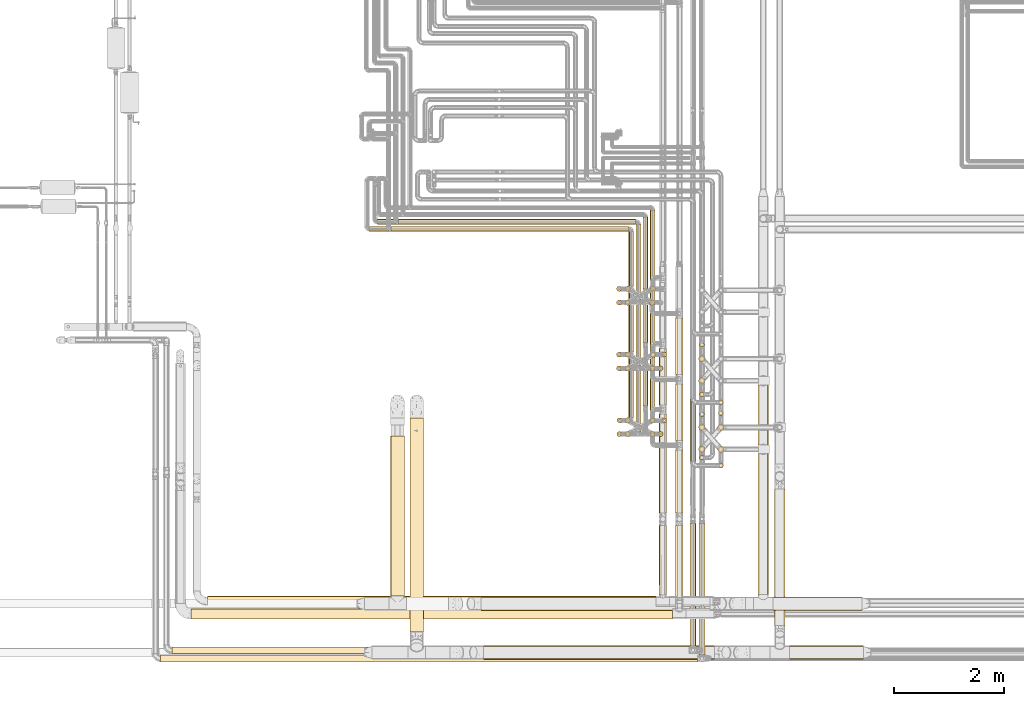
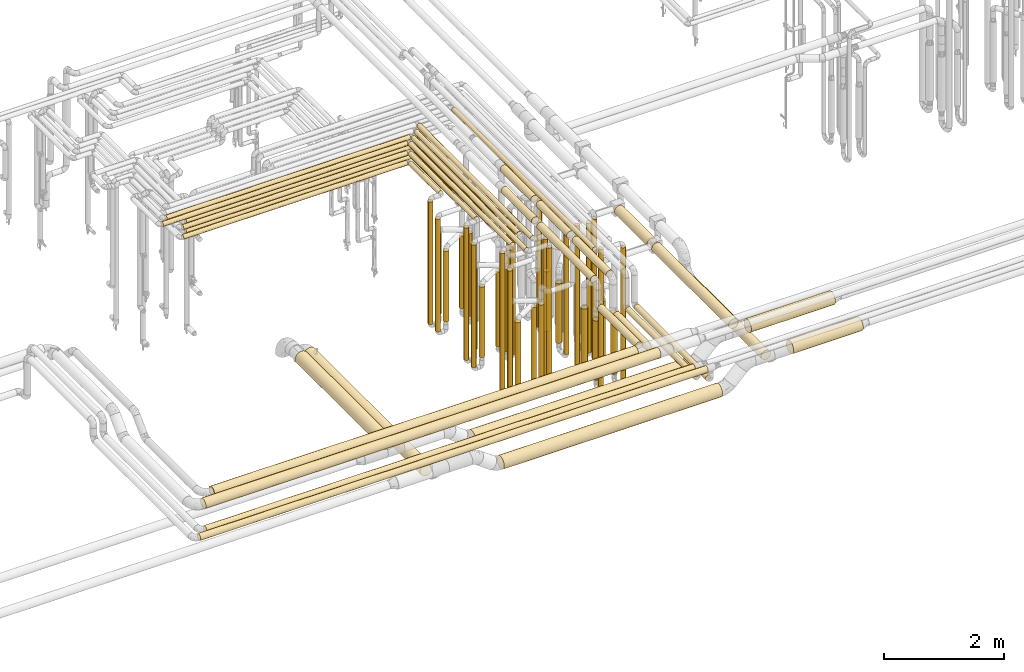
# One storey, part 4 of 824: 76 coverings.
"""IFC2X3 building model written with IfcOpenShell, lengths in millimetres."""

from ifc_helpers import new_model, entity, si_unit, converted_unit, derived_unit, direction, frame, origin, origin_2d_with_axis, place, context, subcontext, project, spatial, circle, extrude, element, save


model = new_model("IFC2X3")

# Units and contexts
model_context = context("Model", 3, precision=0.01, world=origin(), true_north=direction((6.12303176911189e-17, 1.0)))
body_context = subcontext(model_context, "Body", "Model", "MODEL_VIEW")
ifc_project = project(units=[si_unit("LENGTHUNIT", "METRE", prefix="MILLI"), si_unit("AREAUNIT", "SQUARE_METRE"), si_unit("VOLUMEUNIT", "CUBIC_METRE"), converted_unit("PLANEANGLEUNIT", "DEGREE", entity("IfcRatioMeasure", 0.0174532925199433), si_unit("PLANEANGLEUNIT", "RADIAN"), dimensions=[0, 0, 0, 0, 0, 0, 0]), si_unit("MASSUNIT", "GRAM", prefix="KILO"), derived_unit("MASSDENSITYUNIT", [(si_unit("MASSUNIT", "GRAM", prefix="KILO"), 1), (si_unit("LENGTHUNIT", "METRE"), -3)]), derived_unit("MOMENTOFINERTIAUNIT", [(si_unit("LENGTHUNIT", "METRE"), 4)]), si_unit("TIMEUNIT", "SECOND"), si_unit("FREQUENCYUNIT", "HERTZ"), si_unit("THERMODYNAMICTEMPERATUREUNIT", "DEGREE_CELSIUS"), derived_unit("THERMALTRANSMITTANCEUNIT", [(si_unit("MASSUNIT", "GRAM", prefix="KILO"), 1), (si_unit("THERMODYNAMICTEMPERATUREUNIT", "KELVIN"), -1), (si_unit("TIMEUNIT", "SECOND"), -3)]), derived_unit("VOLUMETRICFLOWRATEUNIT", [(si_unit("LENGTHUNIT", "METRE"), 3), (si_unit("TIMEUNIT", "SECOND"), -1)]), derived_unit("MASSFLOWRATEUNIT", [(si_unit("MASSUNIT", "GRAM", prefix="KILO"), 1), (si_unit("TIMEUNIT", "SECOND"), -1)]), derived_unit("ROTATIONALFREQUENCYUNIT", [(si_unit("TIMEUNIT", "SECOND"), -1)]), si_unit("ELECTRICCURRENTUNIT", "AMPERE"), si_unit("ELECTRICVOLTAGEUNIT", "VOLT"), si_unit("POWERUNIT", "WATT"), si_unit("FORCEUNIT", "NEWTON", prefix="KILO"), si_unit("ILLUMINANCEUNIT", "LUX"), si_unit("LUMINOUSFLUXUNIT", "LUMEN"), si_unit("LUMINOUSINTENSITYUNIT", "CANDELA"), derived_unit("USERDEFINED", [(si_unit("MASSUNIT", "GRAM", prefix="KILO"), -1), (si_unit("LENGTHUNIT", "METRE"), -2), (si_unit("TIMEUNIT", "SECOND"), 3), (si_unit("LUMINOUSFLUXUNIT", "LUMEN"), 1)]), derived_unit("LINEARVELOCITYUNIT", [(si_unit("LENGTHUNIT", "METRE"), 1), (si_unit("TIMEUNIT", "SECOND"), -1)]), si_unit("PRESSUREUNIT", "PASCAL"), derived_unit("USERDEFINED", [(si_unit("LENGTHUNIT", "METRE"), -2), (si_unit("MASSUNIT", "GRAM", prefix="KILO"), 1), (si_unit("TIMEUNIT", "SECOND"), -2)]), derived_unit("LINEARFORCEUNIT", [(si_unit("MASSUNIT", "GRAM", prefix="KILO"), 1), (si_unit("LENGTHUNIT", "METRE"), 1), (si_unit("TIMEUNIT", "SECOND"), -2), (si_unit("LENGTHUNIT", "METRE"), -1)]), derived_unit("PLANARFORCEUNIT", [(si_unit("MASSUNIT", "GRAM", prefix="KILO"), 1), (si_unit("LENGTHUNIT", "METRE"), 1), (si_unit("TIMEUNIT", "SECOND"), -2), (si_unit("LENGTHUNIT", "METRE"), -2)])], contexts=[model_context])

# Site, building, storey
site_placement = place(None, origin())
site = spatial("IfcSite", under=ifc_project, at=site_placement, CompositionType="ELEMENT")
building_placement = place(site_placement, origin())
building = spatial("IfcBuilding", under=site, at=building_placement, CompositionType="ELEMENT")
storey_placement = place(building_placement, frame((0.0, 0.0, 28200.0)))
storey = spatial("IfcBuildingStorey", under=building, at=storey_placement, CompositionType="ELEMENT", Elevation=28200.0)

# Coverings
covering_1_placement = place(storey_placement, frame((35072.29, 11508.46, 448.0)))
element("IfcCovering", 1, at=covering_1_placement, inside=storey, PredefinedType="INSULATION", context=body_context, shape_type="SweptSolid", body=[
    extrude(circle(Radius=46.15, at=origin_2d_with_axis()), frame((47.75, 47.75, 0.0), z_axis=(0.0, 0.0, 1.0), x_axis=(0.0, -1.0, 0.0)), (0.0, 0.0, 1.0), 2504.00000000002),
])
covering_2_placement = place(storey_placement, frame((35895.3, 11758.46, 448.0)))
element("IfcCovering", 2, at=covering_2_placement, inside=storey, PredefinedType="INSULATION", context=body_context, shape_type="SweptSolid", body=[
    extrude(circle(Radius=46.15, at=origin_2d_with_axis()), frame((47.75, 47.75, 0.0)), (0.0, 0.0, 1.0), 2704.00000000003),
])
covering_3_placement = place(storey_placement, frame((35077.29, 10309.34, 448.0)))
element("IfcCovering", 3, at=covering_3_placement, inside=storey, PredefinedType="INSULATION", context=body_context, shape_type="SweptSolid", body=[
    extrude(circle(Radius=46.15, at=origin_2d_with_axis()), frame((47.75, 47.75, 0.0), z_axis=(0.0, 0.0, 1.0), x_axis=(0.0, -1.0, 0.0)), (0.0, 0.0, 1.0), 2704.00000000001),
])
covering_4_placement = place(storey_placement, frame((35900.3, 10558.46, 448.0)))
element("IfcCovering", 4, at=covering_4_placement, inside=storey, PredefinedType="INSULATION", context=body_context, shape_type="SweptSolid", body=[
    extrude(circle(Radius=46.15, at=origin_2d_with_axis()), frame((47.75, 47.75, 0.0), z_axis=(0.0, 0.0, 1.0), x_axis=(-1.0, 0.0, 0.0)), (0.0, 0.0, 1.0), 2904.00000000001),
])
covering_5_placement = place(storey_placement, frame((35847.22, 8921.39, 3479.16)))
element("IfcCovering", 5, at=covering_5_placement, inside=storey, PredefinedType="INSULATION", context=body_context, shape_type="SweptSolid", body=[
    extrude(circle(Radius=69.25, at=origin_2d_with_axis()), frame((70.85, 0.0, 70.85), z_axis=(0.0, 1.0, -9.11558874934062e-08), x_axis=(1.0, 0.0, 0.0)), (0.0, 0.0, 1.0), 1798.81487069227),
])
covering_6_placement = place(storey_placement, frame((35847.2, 7422.68, 3029.15)))
element("IfcCovering", 6, at=covering_6_placement, inside=storey, PredefinedType="INSULATION", context=body_context, shape_type="SweptSolid", body=[
    extrude(circle(Radius=69.25, at=origin_2d_with_axis()), frame((70.85, 1270.71, 70.85), z_axis=(0.000807635041357438, -0.999999673862767, 0.0), x_axis=(0.999999673862767, 0.000807635041357438, 0.0)), (0.0, 0.0, 1.0), 1270.65564093337),
])
covering_7_placement = place(storey_placement, frame((35682.29, 11854.2, 3152.25)))
element("IfcCovering", 7, at=covering_7_placement, inside=storey, PredefinedType="INSULATION", context=body_context, shape_type="SweptSolid", body=[
    extrude(circle(Radius=46.15, at=origin_2d_with_axis()), frame((47.75, 0.0, 47.75), z_axis=(0.0, 1.0, 0.0), x_axis=(-1.0, 0.0, 0.0)), (0.0, 0.0, 1.0), 2587.79707398043),
])
covering_8_placement = place(storey_placement, frame((35552.35, 12031.2, 3152.25)))
element("IfcCovering", 8, at=covering_8_placement, inside=storey, PredefinedType="INSULATION", context=body_context, shape_type="SweptSolid", body=[
    extrude(circle(Radius=46.15, at=origin_2d_with_axis()), frame((47.75, 0.0, 47.75), z_axis=(0.0, 1.0, 0.0), x_axis=(1.0, 0.0, 0.0)), (0.0, 0.0, 1.0), 2280.79727405418),
])
covering_9_placement = place(storey_placement, frame((35682.29, 10654.2, 3352.25)))
element("IfcCovering", 9, at=covering_9_placement, inside=storey, PredefinedType="INSULATION", context=body_context, shape_type="SweptSolid", body=[
    extrude(circle(Radius=46.15, at=origin_2d_with_axis()), frame((47.75, 0.0, 47.75), z_axis=(0.0, 1.0, 0.0), x_axis=(1.0, 0.0, 0.0)), (0.0, 0.0, 1.0), 3787.79707398042),
])
covering_10_placement = place(storey_placement, frame((35552.35, 10876.38, 3352.25)))
element("IfcCovering", 10, at=covering_10_placement, inside=storey, PredefinedType="INSULATION", context=body_context, shape_type="SweptSolid", body=[
    extrude(circle(Radius=46.15, at=origin_2d_with_axis()), frame((47.75, 0.0, 47.75), z_axis=(0.0, 1.0, 0.0), x_axis=(1.0, 0.0, 0.0)), (0.0, 0.0, 1.0), 3435.62396825438),
])
covering_11_placement = place(storey_placement, frame((35847.22, 10892.2, 3479.16)))
element("IfcCovering", 11, at=covering_11_placement, inside=storey, PredefinedType="INSULATION", context=body_context, shape_type="SweptSolid", body=[
    extrude(circle(Radius=69.25, at=origin_2d_with_axis()), frame((70.85, 0.0, 70.85), z_axis=(0.0, 1.0, -9.11558935474048e-08), x_axis=(1.0, 0.0, 0.0)), (0.0, 0.0, 1.0), 1027.87693556046),
])
covering_12_placement = place(storey_placement, frame((35228.27, 10306.49, 604.0)))
element("IfcCovering", 12, at=covering_12_placement, inside=storey, PredefinedType="INSULATION", context=body_context, shape_type="SweptSolid", body=[
    extrude(circle(Radius=49.0, at=origin_2d_with_axis()), frame((50.6, 50.6, 0.0), z_axis=(0.0, 1.97430995600526e-06, 1.0), x_axis=(-1.0, 0.0, 0.0)), (0.0, 0.0, 1.0), 1439.00000000281),
])
covering_13_placement = place(storey_placement, frame((35677.45, 10555.61, 559.0)))
element("IfcCovering", 13, at=covering_13_placement, inside=storey, PredefinedType="INSULATION", context=body_context, shape_type="SweptSolid", body=[
    extrude(circle(Radius=49.0, at=origin_2d_with_axis()), frame((50.6, 50.6, 0.0), z_axis=(0.0, 0.0, 1.0), x_axis=(-1.0, 0.0, 0.0)), (0.0, 0.0, 1.0), 1484.0),
])
covering_14_placement = place(storey_placement, frame((35224.44, 11505.05, 603.98)))
element("IfcCovering", 14, at=covering_14_placement, inside=storey, PredefinedType="INSULATION", context=body_context, shape_type="SweptSolid", body=[
    extrude(circle(Radius=49.0, at=origin_2d_with_axis()), frame((50.6, 51.21, 0.02), z_axis=(0.0, -0.000429537009763512, 0.999999907748974), x_axis=(1.0, 0.0, 0.0)), (0.0, 0.0, 1.0), 1438.97359676792),
])
covering_15_placement = place(storey_placement, frame((35686.26, 11755.07, 511.98)))
element("IfcCovering", 15, at=covering_15_placement, inside=storey, PredefinedType="INSULATION", context=body_context, shape_type="SweptSolid", body=[
    extrude(circle(Radius=49.0, at=origin_2d_with_axis()), frame((50.6, 51.09, 0.02), z_axis=(0.0, -0.000321811119658756, 0.9999999482188), x_axis=(1.0, 0.0, 0.0)), (0.0, 0.0, 1.0), 1531.00008703173),
])
covering_16_placement = place(storey_placement, frame((27310.33, 6983.4, 3003.4)))
element("IfcCovering", 16, at=covering_16_placement, inside=storey, PredefinedType="INSULATION", context=body_context, shape_type="SweptSolid", body=[
    extrude(circle(Radius=95.0, at=origin_2d_with_axis()), frame((0.0, 96.6, 96.6), z_axis=(1.0, 0.0, 0.0), x_axis=(0.0, -0.707106781186544, -0.707106781186551)), (0.0, 0.0, 1.0), 8785.70070250989),
])
covering_17_placement = place(storey_placement, frame((31094.52, 14182.26, 3152.25)))
element("IfcCovering", 17, at=covering_17_placement, inside=storey, PredefinedType="INSULATION", context=body_context, shape_type="SweptSolid", body=[
    extrude(circle(Radius=46.15, at=origin_2d_with_axis()), frame((0.0, 47.75, 47.75), z_axis=(1.0, 0.0, 0.0), x_axis=(0.0, -1.0, 0.0)), (0.0, 0.0, 1.0), 4327.51165000006),
])
covering_18_placement = place(storey_placement, frame((30964.52, 14052.26, 3152.25)))
element("IfcCovering", 18, at=covering_18_placement, inside=storey, PredefinedType="INSULATION", context=body_context, shape_type="SweptSolid", body=[
    extrude(circle(Radius=46.15, at=origin_2d_with_axis()), frame((0.0, 47.75, 47.75), z_axis=(1.0, 0.0, 0.0), x_axis=(0.0, -1.0, 0.0)), (0.0, 0.0, 1.0), 4327.51165000005),
])
covering_19_placement = place(storey_placement, frame((30718.34, 14182.26, 3352.25)))
element("IfcCovering", 19, at=covering_19_placement, inside=storey, PredefinedType="INSULATION", context=body_context, shape_type="SweptSolid", body=[
    extrude(circle(Radius=46.15, at=origin_2d_with_axis()), frame((0.0, 47.75, 47.75), z_axis=(1.0, 0.0, 0.0), x_axis=(0.0, -1.0, 0.0)), (0.0, 0.0, 1.0), 4703.69587000002),
])
covering_20_placement = place(storey_placement, frame((30569.52, 14052.26, 3352.25)))
element("IfcCovering", 20, at=covering_20_placement, inside=storey, PredefinedType="INSULATION", context=body_context, shape_type="SweptSolid", body=[
    extrude(circle(Radius=46.15, at=origin_2d_with_axis()), frame((0.0, 47.75, 47.75), z_axis=(1.0, 0.0, 0.0), x_axis=(0.0, -1.0, 0.0)), (0.0, 0.0, 1.0), 4722.51165000002),
])
covering_21_placement = place(storey_placement, frame((35072.29, 11758.46, 448.0)))
element("IfcCovering", 21, at=covering_21_placement, inside=storey, PredefinedType="INSULATION", context=body_context, shape_type="SweptSolid", body=[
    extrude(circle(Radius=46.15, at=origin_2d_with_axis()), frame((47.75, 47.75, 0.0), z_axis=(0.0, 0.0, 1.0), x_axis=(0.0, -1.0, 0.0)), (0.0, 0.0, 1.0), 2704.00000000002),
])
covering_22_placement = place(storey_placement, frame((35826.04, 11508.42, 448.0)))
element("IfcCovering", 22, at=covering_22_placement, inside=storey, PredefinedType="INSULATION", context=body_context, shape_type="SweptSolid", body=[
    extrude(circle(Radius=46.15, at=origin_2d_with_axis()), frame((47.75, 47.75, 0.0), z_axis=(0.0, 0.0, 1.0), x_axis=(-1.0, 0.0, 0.0)), (0.0, 0.0, 1.0), 2704.00000000003),
])
covering_23_placement = place(storey_placement, frame((35077.29, 10561.4, 448.0)))
element("IfcCovering", 23, at=covering_23_placement, inside=storey, PredefinedType="INSULATION", context=body_context, shape_type="SweptSolid", body=[
    extrude(circle(Radius=46.15, at=origin_2d_with_axis()), frame((47.75, 47.75, 0.0), z_axis=(0.0, 0.0, 1.0), x_axis=(0.0, -1.0, 0.0)), (0.0, 0.0, 1.0), 2904.0),
])
covering_24_placement = place(storey_placement, frame((35831.04, 10308.42, 448.0)))
element("IfcCovering", 24, at=covering_24_placement, inside=storey, PredefinedType="INSULATION", context=body_context, shape_type="SweptSolid", body=[
    extrude(circle(Radius=46.15, at=origin_2d_with_axis()), frame((47.75, 47.75, 0.0)), (0.0, 0.0, 1.0), 2904.00000000001),
])
covering_25_placement = place(storey_placement, frame((36149.19, 8921.39, 3479.16)))
element("IfcCovering", 25, at=covering_25_placement, inside=storey, PredefinedType="INSULATION", context=body_context, shape_type="SweptSolid", body=[
    extrude(circle(Radius=69.25, at=origin_2d_with_axis()), frame((70.85, 0.0, 70.85), z_axis=(0.0, 1.0, -8.51254598960259e-08), x_axis=(1.0, 0.0, 0.0)), (0.0, 0.0, 1.0), 1148.81413940413),
])
covering_26_placement = place(storey_placement, frame((36149.19, 7376.95, 2779.15)))
element("IfcCovering", 26, at=covering_26_placement, inside=storey, PredefinedType="INSULATION", context=body_context, shape_type="SweptSolid", body=[
    extrude(circle(Radius=69.25, at=origin_2d_with_axis()), frame((70.85, 0.0, 70.85), z_axis=(0.0, 1.0, 0.0), x_axis=(1.0, 0.0, 0.0)), (0.0, 0.0, 1.0), 1316.44024231723),
])
covering_27_placement = place(storey_placement, frame((35292.29, 11854.2, 3152.25)))
element("IfcCovering", 27, at=covering_27_placement, inside=storey, PredefinedType="INSULATION", context=body_context, shape_type="SweptSolid", body=[
    extrude(circle(Radius=46.15, at=origin_2d_with_axis()), frame((47.75, 0.0, 47.75), z_axis=(0.0, 1.0, 0.0), x_axis=(-1.0, 0.0, 0.0)), (0.0, 0.0, 1.0), 2197.79707405417),
])
covering_28_placement = place(storey_placement, frame((35422.29, 11604.17, 3152.25)))
element("IfcCovering", 28, at=covering_28_placement, inside=storey, PredefinedType="INSULATION", context=body_context, shape_type="SweptSolid", body=[
    extrude(circle(Radius=46.15, at=origin_2d_with_axis()), frame((47.75, 0.0, 47.75), z_axis=(0.0, 1.0, 0.0), x_axis=(-1.0, 0.0, 0.0)), (0.0, 0.0, 1.0), 2577.83166077068),
])
covering_29_placement = place(storey_placement, frame((35292.29, 10657.14, 3352.25)))
element("IfcCovering", 29, at=covering_29_placement, inside=storey, PredefinedType="INSULATION", context=body_context, shape_type="SweptSolid", body=[
    extrude(circle(Radius=46.15, at=origin_2d_with_axis()), frame((47.75, 0.0, 47.75), z_axis=(0.0, 1.0, 0.0), x_axis=(-1.0, 0.0, 0.0)), (0.0, 0.0, 1.0), 3394.85688841738),
])
covering_30_placement = place(storey_placement, frame((35422.29, 10404.17, 3352.25)))
element("IfcCovering", 30, at=covering_30_placement, inside=storey, PredefinedType="INSULATION", context=body_context, shape_type="SweptSolid", body=[
    extrude(circle(Radius=46.15, at=origin_2d_with_axis()), frame((47.75, 0.0, 47.75), z_axis=(0.0, 1.0, 0.0), x_axis=(1.0, 0.0, 0.0)), (0.0, 0.0, 1.0), 3777.83166077068),
])
covering_31_placement = place(storey_placement, frame((36149.19, 10242.2, 3479.15)))
element("IfcCovering", 31, at=covering_31_placement, inside=storey, PredefinedType="INSULATION", context=body_context, shape_type="SweptSolid", body=[
    extrude(circle(Radius=69.25, at=origin_2d_with_axis()), frame((70.85, 0.0, 70.85), z_axis=(0.0, 1.0, -9.11558977614012e-08), x_axis=(1.0, 0.0, 0.0)), (0.0, 0.0, 1.0), 1027.87693556044),
])
covering_32_placement = place(storey_placement, frame((36149.19, 11442.08, 3479.15)))
element("IfcCovering", 32, at=covering_32_placement, inside=storey, PredefinedType="INSULATION", context=body_context, shape_type="SweptSolid", body=[
    extrude(circle(Radius=69.25, at=origin_2d_with_axis()), frame((70.85, 0.0, 70.85), z_axis=(0.0, 1.0, -9.11558897760429e-08), x_axis=(1.0, 0.0, 0.0)), (0.0, 0.0, 1.0), 1028.00000000001),
])
covering_33_placement = place(storey_placement, frame((35677.45, 10305.57, 559.0)))
element("IfcCovering", 33, at=covering_33_placement, inside=storey, PredefinedType="INSULATION", context=body_context, shape_type="SweptSolid", body=[
    extrude(circle(Radius=49.0, at=origin_2d_with_axis()), frame((50.6, 50.6, 0.0), z_axis=(0.0, 0.0, 1.0), x_axis=(-1.0, 0.0, 0.0)), (0.0, 0.0, 1.0), 1688.99999999998),
])
covering_34_placement = place(storey_placement, frame((35226.14, 10558.53, 604.0)))
element("IfcCovering", 34, at=covering_34_placement, inside=storey, PredefinedType="INSULATION", context=body_context, shape_type="SweptSolid", body=[
    extrude(circle(Radius=49.0, at=origin_2d_with_axis()), frame((50.6, 50.61, 0.0), z_axis=(0.0, -1.10407019482887e-05, 1.0), x_axis=(-1.0, 0.0, 0.0)), (0.0, 0.0, 1.0), 1644.00000010021),
])
covering_35_placement = place(storey_placement, frame((35678.19, 11503.87, 558.95)))
element("IfcCovering", 35, at=covering_35_placement, inside=storey, PredefinedType="INSULATION", context=body_context, shape_type="SweptSolid", body=[
    extrude(circle(Radius=49.0, at=origin_2d_with_axis()), frame((50.6, 52.3, 0.05), z_axis=(0.0, -0.00101019809551677, 0.999999489749774), x_axis=(0.0, -0.999999489749774, -0.00101019809551677)), (0.0, 0.0, 1.0), 1689.00086181307),
])
covering_36_placement = place(storey_placement, frame((35225.64, 11757.53, 604.0)))
element("IfcCovering", 36, at=covering_36_placement, inside=storey, PredefinedType="INSULATION", context=body_context, shape_type="SweptSolid", body=[
    extrude(circle(Radius=49.0, at=origin_2d_with_axis()), frame((50.6, 50.6, 0.0), z_axis=(0.0, 0.0, 1.0), x_axis=(-1.0, 0.0, 0.0)), (0.0, 0.0, 1.0), 1644.0),
])
covering_37_placement = place(storey_placement, frame((35552.35, 13004.17, 2952.25)))
element("IfcCovering", 37, at=covering_37_placement, inside=storey, PredefinedType="INSULATION", context=body_context, shape_type="SweptSolid", body=[
    extrude(circle(Radius=46.15, at=origin_2d_with_axis()), frame((47.75, 0.0, 47.75), z_axis=(0.0, 1.0, 0.0), x_axis=(1.0, 0.0, 0.0)), (0.0, 0.0, 1.0), 1307.82580405416),
])
covering_38_placement = place(storey_placement, frame((35072.29, 12708.46, 448.0)))
element("IfcCovering", 38, at=covering_38_placement, inside=storey, PredefinedType="INSULATION", context=body_context, shape_type="SweptSolid", body=[
    extrude(circle(Radius=46.15, at=origin_2d_with_axis()), frame((47.75, 47.75, 0.0), z_axis=(0.0, 0.0, 1.0), x_axis=(0.0, 1.0, 0.0)), (0.0, 0.0, 1.0), 2303.60885615262),
])
covering_39_placement = place(storey_placement, frame((31094.52, 14182.26, 2952.25)))
element("IfcCovering", 39, at=covering_39_placement, inside=storey, PredefinedType="INSULATION", context=body_context, shape_type="SweptSolid", body=[
    extrude(circle(Radius=46.15, at=origin_2d_with_axis()), frame((0.0, 47.75, 47.75), z_axis=(1.0, 0.0, 0.0), x_axis=(0.0, 1.0, 0.0)), (0.0, 0.0, 1.0), 4327.51165000003),
])
covering_40_placement = place(storey_placement, frame((35422.29, 12804.17, 2952.25)))
element("IfcCovering", 40, at=covering_40_placement, inside=storey, PredefinedType="INSULATION", context=body_context, shape_type="SweptSolid", body=[
    extrude(circle(Radius=46.15, at=origin_2d_with_axis()), frame((47.75, 0.0, 47.75), z_axis=(0.0, 1.0, 0.0), x_axis=(1.0, 0.0, 0.0)), (0.0, 0.0, 1.0), 1377.83166077068),
])
covering_41_placement = place(storey_placement, frame((35682.29, 13054.2, 2952.25)))
element("IfcCovering", 41, at=covering_41_placement, inside=storey, PredefinedType="INSULATION", context=body_context, shape_type="SweptSolid", body=[
    extrude(circle(Radius=46.15, at=origin_2d_with_axis()), frame((47.75, 0.0, 47.75), z_axis=(0.0, 1.0, 0.0), x_axis=(1.0, 0.0, 0.0)), (0.0, 0.0, 1.0), 1387.79707398041),
])
covering_42_placement = place(storey_placement, frame((30964.52, 14052.26, 2952.25)))
element("IfcCovering", 42, at=covering_42_placement, inside=storey, PredefinedType="INSULATION", context=body_context, shape_type="SweptSolid", body=[
    extrude(circle(Radius=46.15, at=origin_2d_with_axis()), frame((0.0, 47.75, 47.75), z_axis=(1.0, 0.0, 0.0), x_axis=(0.0, 1.0, 0.0)), (0.0, 0.0, 1.0), 4327.51165000003),
])
covering_43_placement = place(storey_placement, frame((35292.29, 13054.2, 2952.25)))
element("IfcCovering", 43, at=covering_43_placement, inside=storey, PredefinedType="INSULATION", context=body_context, shape_type="SweptSolid", body=[
    extrude(circle(Radius=46.15, at=origin_2d_with_axis()), frame((47.75, 0.0, 47.75), z_axis=(0.0, 1.0, 0.0), x_axis=(1.0, 0.0, 0.0)), (0.0, 0.0, 1.0), 997.797074054168),
])
covering_44_placement = place(storey_placement, frame((35072.29, 12958.46, 448.0)))
element("IfcCovering", 44, at=covering_44_placement, inside=storey, PredefinedType="INSULATION", context=body_context, shape_type="SweptSolid", body=[
    extrude(circle(Radius=46.15, at=origin_2d_with_axis()), frame((47.75, 47.75, 0.0), z_axis=(0.0, 0.0, 1.0), x_axis=(0.0, 1.0, 0.0)), (0.0, 0.0, 1.0), 2504.0),
])
covering_45_placement = place(storey_placement, frame((35683.54, 12960.08, 559.0)))
element("IfcCovering", 45, at=covering_45_placement, inside=storey, PredefinedType="INSULATION", context=body_context, shape_type="SweptSolid", body=[
    extrude(circle(Radius=49.0, at=origin_2d_with_axis()), frame((50.6, 50.6, 0.0), z_axis=(0.0, 0.0, 1.0), x_axis=(-1.0, 0.0, 0.0)), (0.0, 0.0, 1.0), 1484.0),
])
covering_46_placement = place(storey_placement, frame((35224.75, 12955.94, 604.0)))
element("IfcCovering", 46, at=covering_46_placement, inside=storey, PredefinedType="INSULATION", context=body_context, shape_type="SweptSolid", body=[
    extrude(circle(Radius=49.0, at=origin_2d_with_axis()), frame((50.6, 50.6, 0.0), z_axis=(0.0, 0.0, 1.0), x_axis=(-1.0, 0.0, 0.0)), (0.0, 0.0, 1.0), 1644.0),
])
covering_47_placement = place(storey_placement, frame((35674.44, 12703.87, 559.0)))
element("IfcCovering", 47, at=covering_47_placement, inside=storey, PredefinedType="INSULATION", context=body_context, shape_type="SweptSolid", body=[
    extrude(circle(Radius=49.0, at=origin_2d_with_axis()), frame((50.6, 50.6, 0.0), z_axis=(0.0, 0.0, 1.0), x_axis=(-1.0, 0.0, 0.0)), (0.0, 0.0, 1.0), 1688.99999999999),
])
covering_48_placement = place(storey_placement, frame((35222.31, 12704.26, 604.0)))
element("IfcCovering", 48, at=covering_48_placement, inside=storey, PredefinedType="INSULATION", context=body_context, shape_type="SweptSolid", body=[
    extrude(circle(Radius=49.0, at=origin_2d_with_axis()), frame((50.6, 50.6, 0.0), z_axis=(0.0, 0.0, 1.0), x_axis=(-1.0, 0.0, 0.0)), (0.0, 0.0, 1.0), 1439.0),
])
covering_49_placement = place(storey_placement, frame((37926.3, 7140.11, 2773.77)))
element("IfcCovering", 49, at=covering_49_placement, inside=storey, PredefinedType="INSULATION", context=body_context, shape_type="SweptSolid", body=[
    extrude(circle(Radius=124.5, at=origin_2d_with_axis()), frame((0.0, 126.1, 126.1), z_axis=(1.0, 0.0, 4.27481930386784e-06), x_axis=(0.0, 1.0, 0.0)), (0.0, 0.0, 1.0), 1624.74567570153),
])
covering_50_placement = place(storey_placement, frame((37652.2, 7434.2, 2803.81)))
element("IfcCovering", 50, at=covering_50_placement, inside=storey, PredefinedType="INSULATION", context=body_context, shape_type="SweptSolid", body=[
    extrude(circle(Radius=94.5, at=origin_2d_with_axis()), frame((96.1, 0.0, 96.1), z_axis=(0.0, 1.0, -7.18992412660133e-07), x_axis=(-1.0, 0.0, 0.0)), (0.0, 0.0, 1.0), 2568.50011294233),
])
covering_51_placement = place(storey_placement, frame((36423.44, 9857.02, 3353.4)))
element("IfcCovering", 51, at=covering_51_placement, inside=storey, PredefinedType="INSULATION", context=body_context, shape_type="SweptSolid", body=[
    extrude(circle(Radius=45.0, at=origin_2d_with_axis()), frame((46.6, 0.0, 46.6), z_axis=(0.0, 1.0, 0.0), x_axis=(-1.0, 0.0, 0.0)), (0.0, 0.0, 1.0), 4706.97582205429),
])
covering_52_placement = place(storey_placement, frame((36928.44, 10884.58, 476.0)))
element("IfcCovering", 52, at=covering_52_placement, inside=storey, PredefinedType="INSULATION", context=body_context, shape_type="SweptSolid", body=[
    extrude(circle(Radius=45.0, at=origin_2d_with_axis()), frame((46.6, 46.6, 0.0), z_axis=(0.0, 0.0, 1.0), x_axis=(-1.0, 0.0, 0.0)), (3.39879591138015e-09, 0.0, 1.0), 2647.99999099998),
])
covering_53_placement = place(storey_placement, frame((36583.05, 11943.61, 476.0)))
element("IfcCovering", 53, at=covering_53_placement, inside=storey, PredefinedType="INSULATION", context=body_context, shape_type="SweptSolid", body=[
    extrude(circle(Radius=45.0, at=origin_2d_with_axis()), frame((46.6, 46.6, 0.0)), (0.0, 0.0, 1.0), 2648.0),
])
covering_54_placement = place(storey_placement, frame((36568.8, 11669.36, 565.0)))
element("IfcCovering", 54, at=covering_54_placement, inside=storey, PredefinedType="INSULATION", context=body_context, shape_type="SweptSolid", body=[
    extrude(circle(Radius=59.25, at=origin_2d_with_axis()), frame((60.85, 60.85, 0.0), z_axis=(0.0, 0.0, 1.0), x_axis=(-1.0, 0.0, 0.0)), (0.0, 0.0, 1.0), 1215.99999999999),
])
covering_55_placement = place(storey_placement, frame((36928.44, 9734.43, 476.0)))
element("IfcCovering", 55, at=covering_55_placement, inside=storey, PredefinedType="INSULATION", context=body_context, shape_type="SweptSolid", body=[
    extrude(circle(Radius=45.0, at=origin_2d_with_axis()), frame((46.6, 46.6, 0.0), z_axis=(0.0, 0.0, 1.0), x_axis=(-1.0, 0.0, 0.0)), (3.16011039558362e-09, 0.0, 1.0), 2847.99999099998),
])
covering_56_placement = place(storey_placement, frame((36583.05, 10673.13, 476.0)))
element("IfcCovering", 56, at=covering_56_placement, inside=storey, PredefinedType="INSULATION", context=body_context, shape_type="SweptSolid", body=[
    extrude(circle(Radius=45.0, at=origin_2d_with_axis()), frame((46.6, 46.6, 0.0)), (0.0, 0.0, 1.0), 2847.99999999999),
])
covering_57_placement = place(storey_placement, frame((36568.8, 10419.36, 565.0)))
element("IfcCovering", 57, at=covering_57_placement, inside=storey, PredefinedType="INSULATION", context=body_context, shape_type="SweptSolid", body=[
    extrude(circle(Radius=59.25, at=origin_2d_with_axis()), frame((60.85, 60.85, 0.0), z_axis=(0.0, 0.0, 1.0), x_axis=(-1.0, 0.0, 0.0)), (0.0, 0.0, 1.0), 1215.99999999998),
])
covering_58_placement = place(storey_placement, frame((36914.19, 10019.36, 565.0)))
element("IfcCovering", 58, at=covering_58_placement, inside=storey, PredefinedType="INSULATION", context=body_context, shape_type="SweptSolid", body=[
    extrude(circle(Radius=59.25, at=origin_2d_with_axis()), frame((60.85, 60.85, 0.0), z_axis=(0.0, 0.0, 1.0), x_axis=(0.0, 1.0, 0.0)), (0.0, 0.0, 1.0), 1245.99999099997),
])
covering_59_placement = place(storey_placement, frame((27610.03, 7213.4, 3003.4)))
element("IfcCovering", 59, at=covering_59_placement, inside=storey, PredefinedType="INSULATION", context=body_context, shape_type="SweptSolid", body=[
    extrude(circle(Radius=95.0, at=origin_2d_with_axis()), frame((0.0, 96.6, 96.6), z_axis=(1.0, 0.0, 0.0), x_axis=(0.0, -1.0, 0.0)), (0.0, 0.0, 1.0), 8185.03374931238),
])
covering_60_placement = place(storey_placement, frame((26962.64, 6351.97, 3035.4)))
element("IfcCovering", 60, at=covering_60_placement, inside=storey, PredefinedType="INSULATION", context=body_context, shape_type="SweptSolid", body=[
    extrude(circle(Radius=63.0, at=origin_2d_with_axis()), frame((0.0, 64.6, 64.6), z_axis=(1.0, 0.0, 0.0), x_axis=(0.0, -1.0, 0.0)), (0.0, 0.0, 1.0), 9430.07864615945),
])
covering_61_placement = place(storey_placement, frame((36412.12, 6492.57, 2793.4)))
element("IfcCovering", 61, at=covering_61_placement, inside=storey, PredefinedType="INSULATION", context=body_context, shape_type="SweptSolid", body=[
    extrude(circle(Radius=55.0, at=origin_2d_with_axis()), frame((56.6, 0.0, 56.6), z_axis=(0.0, 1.0, 0.0), x_axis=(-1.0, 0.0, 0.0)), (0.0, 0.0, 1.0), 2238.82114274712),
])
covering_62_placement = place(storey_placement, frame((26758.64, 6201.11, 3035.4)))
element("IfcCovering", 62, at=covering_62_placement, inside=storey, PredefinedType="INSULATION", context=body_context, shape_type="SweptSolid", body=[
    extrude(circle(Radius=63.0, at=origin_2d_with_axis()), frame((0.0, 64.6, 64.6), z_axis=(1.0, 0.0, 0.0), x_axis=(0.0, -1.0, 0.0)), (0.0, 0.0, 1.0), 9795.00564256815),
])
covering_63_placement = place(storey_placement, frame((36573.05, 6341.81, 2793.4)))
element("IfcCovering", 63, at=covering_63_placement, inside=storey, PredefinedType="INSULATION", context=body_context, shape_type="SweptSolid", body=[
    extrude(circle(Radius=55.0, at=origin_2d_with_axis()), frame((56.6, 0.0, 56.6), z_axis=(0.0, 1.0, 2.8092716982407e-07), x_axis=(-1.0, 0.0, 0.0)), (0.0, 0.0, 1.0), 2389.57772043251),
])
covering_64_placement = place(storey_placement, frame((32603.88, 7140.11, 2373.87)))
element("IfcCovering", 64, at=covering_64_placement, inside=storey, PredefinedType="INSULATION", context=body_context, shape_type="SweptSolid", body=[
    extrude(circle(Radius=124.5, at=origin_2d_with_axis()), frame((0.0, 126.1, 126.1), z_axis=(1.0, 0.0, 4.7406801690562e-07), x_axis=(0.0, -1.0, 0.0)), (0.0, 0.0, 1.0), 4174.30145695366),
])
covering_65_placement = place(storey_placement, frame((31303.9, 6749.26, 2423.9)))
element("IfcCovering", 65, at=covering_65_placement, inside=storey, PredefinedType="INSULATION", context=body_context, shape_type="SweptSolid", body=[
    extrude(circle(Radius=124.5, at=origin_2d_with_axis()), frame((126.1, 0.0, 126.1), z_axis=(0.0, 1.0, 0.0), x_axis=(-1.0, 0.0, 0.0)), (0.0, 0.0, 1.0), 3900.73593128801),
])
covering_66_placement = place(storey_placement, frame((38226.3, 6248.9, 2773.9)))
element("IfcCovering", 66, at=covering_66_placement, inside=storey, PredefinedType="INSULATION", context=body_context, shape_type="SweptSolid", body=[
    extrude(circle(Radius=124.5, at=origin_2d_with_axis()), frame((0.0, 126.1, 126.1), z_axis=(1.0, 0.0, 0.0), x_axis=(0.0, 1.0, 0.0)), (0.0, 0.0, 1.0), 1348.80954210606),
])
covering_67_placement = place(storey_placement, frame((37952.2, 6868.2, 2403.9)))
element("IfcCovering", 67, at=covering_67_placement, inside=storey, PredefinedType="INSULATION", context=body_context, shape_type="SweptSolid", body=[
    extrude(circle(Radius=94.5, at=origin_2d_with_axis()), frame((96.1, 0.0, 96.1), z_axis=(0.0, 1.0, 0.0), x_axis=(-1.0, 0.0, 0.0)), (0.0, 0.0, 1.0), 2485.51890325304),
])
covering_68_placement = place(storey_placement, frame((36568.8, 11270.75, 565.0)))
element("IfcCovering", 68, at=covering_68_placement, inside=storey, PredefinedType="INSULATION", context=body_context, shape_type="SweptSolid", body=[
    extrude(circle(Radius=59.25, at=origin_2d_with_axis()), frame((60.85, 60.85, 0.0), z_axis=(0.0, 0.0, 1.0), x_axis=(0.0, -1.0, 0.0)), (0.0, 0.0, 1.0), 1215.99999099996),
])
covering_69_placement = place(storey_placement, frame((36583.05, 11034.58, 476.0)))
element("IfcCovering", 69, at=covering_69_placement, inside=storey, PredefinedType="INSULATION", context=body_context, shape_type="SweptSolid", body=[
    extrude(circle(Radius=45.0, at=origin_2d_with_axis()), frame((46.6, 46.6, 0.0), z_axis=(0.0, 0.0, 1.0), x_axis=(0.0, -1.0, 0.0)), (0.0, 0.0, 1.0), 2647.99999099998),
])
covering_70_placement = place(storey_placement, frame((36928.44, 10693.61, 476.0)))
element("IfcCovering", 70, at=covering_70_placement, inside=storey, PredefinedType="INSULATION", context=body_context, shape_type="SweptSolid", body=[
    extrude(circle(Radius=45.0, at=origin_2d_with_axis()), frame((46.6, 46.6, 0.0)), (0.0, 0.0, 1.0), 2848.0),
])
covering_71_placement = place(storey_placement, frame((36914.19, 10419.36, 565.0)))
element("IfcCovering", 71, at=covering_71_placement, inside=storey, PredefinedType="INSULATION", context=body_context, shape_type="SweptSolid", body=[
    extrude(circle(Radius=59.25, at=origin_2d_with_axis()), frame((60.85, 60.85, 0.0), z_axis=(0.0, 0.0, 1.0), x_axis=(-1.0, 0.0, 0.0)), (0.0, 0.0, 1.0), 1245.99999999999),
])
covering_72_placement = place(storey_placement, frame((36568.8, 10020.75, 565.0)))
element("IfcCovering", 72, at=covering_72_placement, inside=storey, PredefinedType="INSULATION", context=body_context, shape_type="SweptSolid", body=[
    extrude(circle(Radius=59.25, at=origin_2d_with_axis()), frame((60.85, 60.85, 0.0), z_axis=(0.0, 0.0, 1.0), x_axis=(0.0, -1.0, 0.0)), (0.0, 0.0, 1.0), 1215.99999099995),
])
covering_73_placement = place(storey_placement, frame((36583.05, 9879.58, 476.0)))
element("IfcCovering", 73, at=covering_73_placement, inside=storey, PredefinedType="INSULATION", context=body_context, shape_type="SweptSolid", body=[
    extrude(circle(Radius=45.0, at=origin_2d_with_axis()), frame((46.6, 46.6, 0.0), z_axis=(0.0, 0.0, 1.0), x_axis=(0.0, -1.0, 0.0)), (0.0, 0.0, 1.0), 2847.99999099997),
])
covering_74_placement = place(storey_placement, frame((32643.13, 6248.9, 2373.9)))
element("IfcCovering", 74, at=covering_74_placement, inside=storey, PredefinedType="INSULATION", context=body_context, shape_type="SweptSolid", body=[
    extrude(circle(Radius=124.5, at=origin_2d_with_axis()), frame((0.0, 126.1, 126.1), z_axis=(1.0, 0.0, 0.0), x_axis=(0.0, 1.0, 0.0)), (0.0, 0.0, 1.0), 4214.83070096532),
])
covering_75_placement = place(storey_placement, frame((37652.2, 10157.7, 2803.81)))
element("IfcCovering", 75, at=covering_75_placement, inside=storey, PredefinedType="INSULATION", context=body_context, shape_type="SweptSolid", body=[
    extrude(circle(Radius=94.5, at=origin_2d_with_axis()), frame((96.1, 0.0, 96.1), z_axis=(0.0, 1.0, -7.18992411449206e-07), x_axis=(-1.0, 0.0, 0.0)), (0.0, 0.0, 1.0), 1095.00000000033),
])
covering_76_placement = place(storey_placement, frame((30953.9, 7406.2, 2673.9)))
element("IfcCovering", 76, at=covering_76_placement, inside=storey, PredefinedType="INSULATION", context=body_context, shape_type="SweptSolid", body=[
    extrude(circle(Radius=124.5, at=origin_2d_with_axis()), frame((126.1, 0.0, 126.1), z_axis=(0.0, 1.0, 0.0), x_axis=(1.0, 0.0, 0.0)), (0.0, 0.0, 1.0), 2913.62254577972),
])

save(model, "model.ifc")
